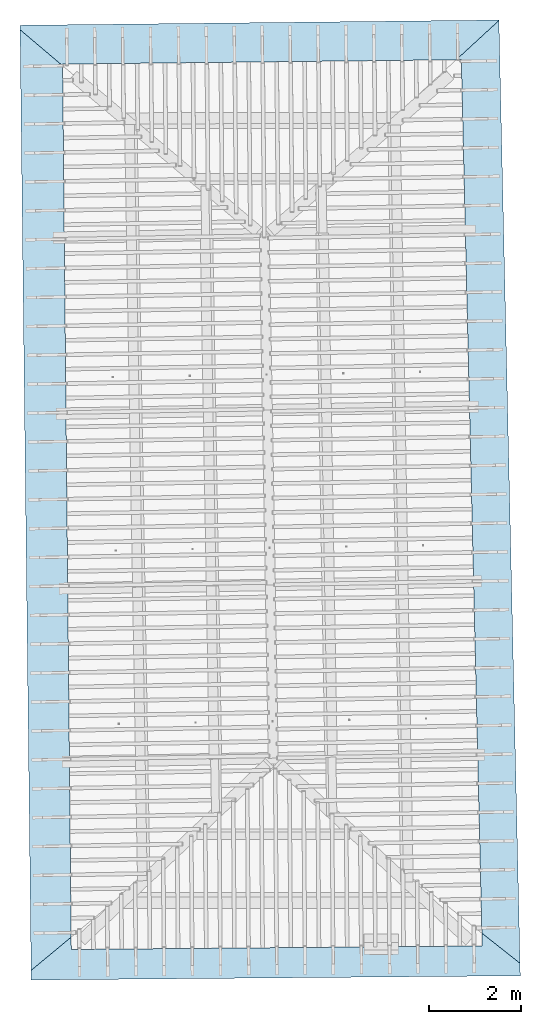
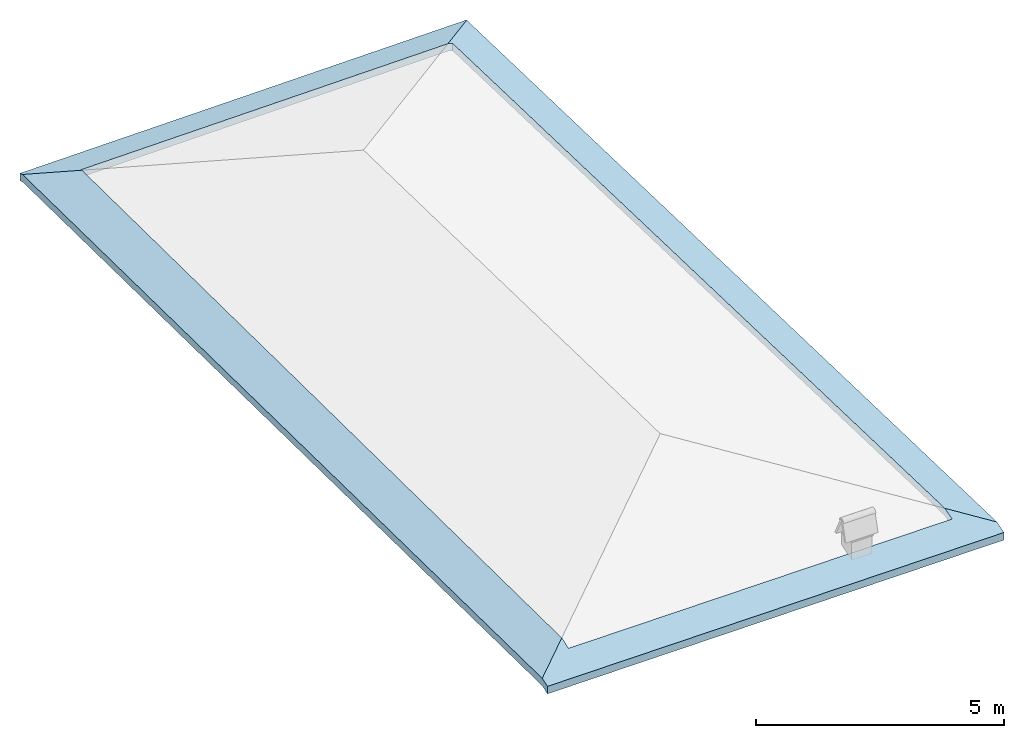
# One storey, part 18 of 19: 1 roof.
"""IFC4 building model written with IfcOpenShell, lengths in metres."""

from ifc_helpers import new_model, entity, si_unit, converted_unit, derived_unit, direction, frame, origin, place, context, subcontext, project, spatial, polygons, material, constituent, constituent_set, type_object, element, save


model = new_model("IFC4")

# Units and contexts
model_context = context("Model", 3, precision=1e-05, world=origin(), true_north=direction((6.123233995736766e-17, 1.0)))
body_context = subcontext(model_context, "Body", "Model", "MODEL_VIEW")
ifc_project = project(units=[si_unit("LENGTHUNIT", "METRE"), si_unit("AREAUNIT", "SQUARE_METRE"), si_unit("VOLUMEUNIT", "CUBIC_METRE"), converted_unit("PLANEANGLEUNIT", "DEGREE", entity("IfcPlaneAngleMeasure", 0.017453292519943278), si_unit("PLANEANGLEUNIT", "RADIAN"), dimensions=[0, 0, 0, 0, 0, 0, 0]), derived_unit("THERMALTRANSMITTANCEUNIT", [(si_unit("MASSUNIT", "GRAM", prefix="KILO"), 1), (si_unit("THERMODYNAMICTEMPERATUREUNIT", "KELVIN"), -1), (si_unit("TIMEUNIT", "SECOND"), -3)])], contexts=[model_context])

# Site, building, storey
site_placement = place(None, origin())
site = spatial("IfcSite", under=ifc_project, at=site_placement, CompositionType="ELEMENT")
building_placement = place(site_placement, origin())
building = spatial("IfcBuilding", under=site, at=building_placement, CompositionType="ELEMENT")
storey_placement = place(building_placement, frame((0.0, 0.0, 3.28)))
storey = spatial("IfcBuildingStorey", under=building, at=storey_placement, Name="Livello Copertura", CompositionType="ELEMENT", Elevation=3.28)

# Roof
ifc_material_1 = material(Name="Coppi")
ifc_constituent_1 = constituent(ifc_material_1, Name="Coppi", fraction=0.7257142857142856)
ifc_material_2 = material(Name="Default - Tetto")
ifc_constituent_2 = constituent(ifc_material_2, Name="Layer", fraction=0.01714285714285714)
ifc_material_3 = material(Name="Copertura, membrana EPDM", Category="Generico")
ifc_constituent_3 = constituent(ifc_material_3, Name="Copertura, membrana EPDM", Category="Generico", fraction=0.11428571428571428)
ifc_material_4 = material(Name="Default")
ifc_constituent_4 = constituent(ifc_material_4, Name="Default", fraction=0.14285714285714285)
ifc_constituent_set = constituent_set(constituents=[ifc_constituent_1, ifc_constituent_2, ifc_constituent_3, ifc_constituent_4], Name="Tetto di base:Copertura Generica")
roof_type = type_object("IfcRoofType", Name="Tetto di base:Copertura Generica", PredefinedType="NOTDEFINED")
roof_placement = place(storey_placement, frame((-5.630830938596697, -3.8869281065743935, -0.08079830422328982)))
element("IfcRoof", 1, at=roof_placement, inside=storey, type_object=roof_type, material=ifc_constituent_set, Name="Tetto di base:Copertura Generica", ObjectType="Tetto di base:Copertura Generica", PredefinedType="NOTDEFINED", context=body_context, shape_type="Tessellation", body=[
    polygons([(10.442382159795823, 20.930450112473824, 0.12220331652369998), (8.881784197001252e-16, 20.815446176055683, 0.07987229227527548), (8.881784197001252e-16, 20.815446176055683, 0.26342559545979194), (10.442382159795823, 20.930450112473824, 0.30575661970821644), (0.2441068060616951, 2.6645352591003757e-15, 0.006675608798976551), (10.908351486760646, 0.09176860377652796, -4.440892098500626e-16), (10.908351486760646, 0.09176860377652751, 0.18508361920766703), (0.2441068060616951, 2.6645352591003757e-15, 0.19175922800664358), (0.24155212344399324, 0.21784258859305972, 0.08168992137722242), (0.0012038802790907965, 20.71278904184406, 0.1123580480627333), (0.929406831540831, 19.92767491712145, 0.3677339997182809), (1.115465870594326, 0.9456000350464997, 0.32912695054904617), (10.442759989079239, 20.913553154571012, 0.12755169770192332), (10.902032935470203, 0.3743414477779625, 0.09731502420973692), (10.068979921056108, 1.0319830311697817, 0.32673658181777343), (9.621388306308226, 20.06451052775701, 0.3608994133334278), (9.518784768905691, 20.063380535528115, 0.3895480446847568), (10.902254022506263, 0.3644541825364014, 0.2789935764522795), (10.442629186391091, 20.91940280046186, 0.30925341694086583), (9.51221791848389, 20.0633082135582, 0.5730747273625538), (9.621388306308226, 20.06451052775701, 0.5425925210523488), (10.069212658062309, 1.022086569028772, 0.5084119256759165), (0.0011352682721810226, 20.71863971663651, 0.2940599105854873), (0.2416680944369931, 0.207953524040827, 0.2633682313466035), (1.1155629556643119, 0.9356952431171077, 0.5107999132210548), (0.9293495784052279, 19.93351598409021, 0.5494389874008565), (0.9290039300157122, 19.968779649032488, 0.3547270416401407), (1.1182057194869826, 0.6660757662415153, 0.23287442136211567), (10.075783521450838, 0.7426797749829706, 0.22710247595759636), (0.9290039300157122, 19.968779649032488, 0.5382803448246563), (10.075783521450838, 0.7426797749829706, 0.41218609516526383), (1.1182057194869826, 0.6660757662415153, 0.41795804056978403)], [[[1, 2, 3, 4]], [[5, 6, 7, 8]], [[9, 10, 11, 12]], [[13, 14, 15, 16, 17]], [[18, 19, 20, 21, 22]], [[23, 24, 25, 26]], [[1, 13, 17, 27, 11, 10, 2]], [[5, 9, 12, 28, 29, 15, 14, 6]], [[4, 3, 23, 26, 30, 20, 19]], [[8, 7, 18, 22, 31, 32, 25, 24]], [[14, 13, 1, 4, 19, 18, 7, 6]], [[10, 9, 5, 8, 24, 23, 3, 2]], [[21, 16, 15, 29, 31, 22]], [[31, 29, 28, 32]], [[32, 28, 12, 11, 27, 30, 26, 25]], [[16, 21, 20, 30, 27, 17]]], closed=True),
])

save(model, "model.ifc")
